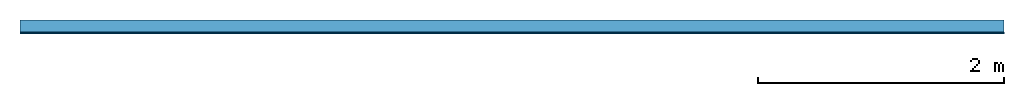
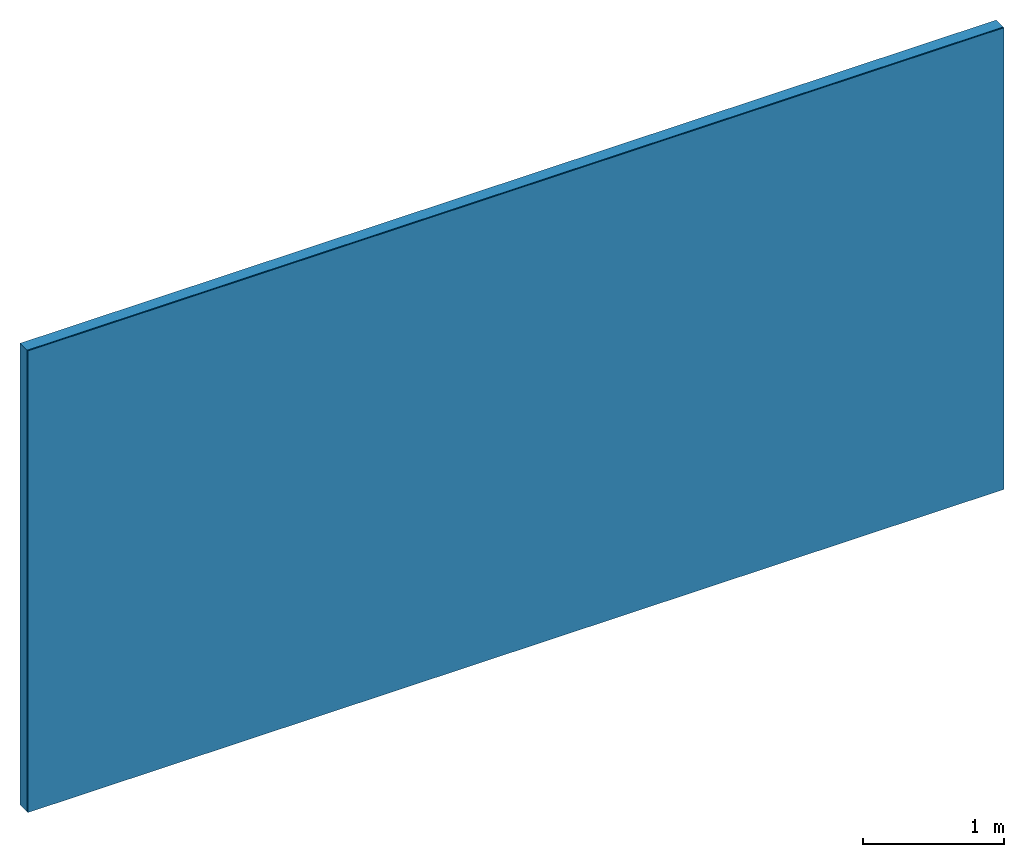
# One storey: 1 member, 1 plate, 1 element without a shape of its own.
"""IFC4 building model written with IfcOpenShell, lengths in metres."""

from ifc_helpers import new_model, si_unit, derived_unit, direction, frame, frame_2d, origin, place, context, project, spatial, rectangle, extrude, material, layer, layer_set, type_object, element, aggregate, save


model = new_model("IFC4")

# Units and contexts
plan_context = context("Plan", 3, precision=1e-05, world=origin(), true_north=direction((0.0, 1.0)))
model_context = context("Model", 3, precision=1e-05, world=origin(), true_north=direction((0.0, 1.0)))
ifc_project = project(units=[si_unit("LENGTHUNIT", "METRE"), derived_unit("SOUNDPRESSUREUNIT", [(si_unit("PRESSUREUNIT", "PASCAL", prefix="MICRO"), 0)]), si_unit("ENERGYUNIT", "JOULE", prefix="MEGA"), si_unit("MASSUNIT", "GRAM", prefix="KILO"), derived_unit("THERMALTRANSMITTANCEUNIT", [(si_unit("POWERUNIT", "WATT"), 1), (si_unit("AREAUNIT", "SQUARE_METRE"), -1), (si_unit("THERMODYNAMICTEMPERATUREUNIT", "KELVIN"), -1)]), derived_unit("AREADENSITYUNIT", [(si_unit("MASSUNIT", "GRAM", prefix="KILO"), 1), (si_unit("AREAUNIT", "SQUARE_METRE"), -1)]), derived_unit("USERDEFINED", [(si_unit("ENERGYUNIT", "JOULE", prefix="MEGA"), 1), (si_unit("AREAUNIT", "SQUARE_METRE"), -1)])], contexts=[plan_context, model_context])

# Site, building, storey
site = spatial("IfcSite", under=ifc_project)
building_placement = place(None, origin())
building = spatial("IfcBuilding", under=site, at=building_placement)
storey_placement = place(building_placement, origin())
storey = spatial("IfcBuildingStorey", under=building, at=storey_placement)

# Wall, member, plate
ifc_layer_1 = layer(None, 0.1, Name="Support")
ifc_material_1 = material(Name="Rigid, of the art")
ifc_layer_2 = layer(ifc_material_1, 0.0, Name="Bond")
ifc_material_2 = material(Name="Mineral Knauf SM 700")
ifc_layer_3 = layer(ifc_material_2, 0.01, Name="Surface")
ifc_layer_set = layer_set([ifc_layer_1, ifc_layer_2, ifc_layer_3])
wall_type = type_object("IfcWallType", Name="D1201", PredefinedType="NOTDEFINED", material=ifc_layer_set)
wall_placement = place(None, frame((0.0, 0.0, 0.0), z_axis=(0.0, -1.0, 0.0), x_axis=(1.0, 0.0, 0.0)))
wall = element("IfcWall", 1, at=wall_placement, inside=storey, type_object=wall_type, material=ifc_layer_set, Name="Wall #1")
ifc_material_3 = material(Name="OSB")
member_placement = place(wall_placement, origin())
member = element("IfcMember", 2, at=member_placement, material=ifc_material_3, Name="Support", context=plan_context, shape_type="SweptSolid", body=[
    extrude(rectangle(XDim=1.0, YDim=0.1, at=frame_2d((0.5, 0.05), x_axis=(1.0, 0.0))), frame((0.0, 4.0, 0.0), z_axis=(0.0, -1.0, 0.0), x_axis=(1.0, 0.0, 0.0)), (0.0, 0.0, 1.0), 4.0),
    extrude(rectangle(XDim=1.0, YDim=0.1, at=frame_2d((0.5, 0.05), x_axis=(1.0, 0.0))), frame((1.0, 4.0, 0.0), z_axis=(0.0, -1.0, 0.0), x_axis=(1.0, 0.0, 0.0)), (0.0, 0.0, 1.0), 4.0),
    extrude(rectangle(XDim=1.0, YDim=0.1, at=frame_2d((0.5, 0.05), x_axis=(1.0, 0.0))), frame((2.0, 4.0, 0.0), z_axis=(0.0, -1.0, 0.0), x_axis=(1.0, 0.0, 0.0)), (0.0, 0.0, 1.0), 4.0),
    extrude(rectangle(XDim=1.0, YDim=0.1, at=frame_2d((0.5, 0.05), x_axis=(1.0, 0.0))), frame((3.0, 4.0, 0.0), z_axis=(0.0, -1.0, 0.0), x_axis=(1.0, 0.0, 0.0)), (0.0, 0.0, 1.0), 4.0),
    extrude(rectangle(XDim=1.0, YDim=0.1, at=frame_2d((0.5, 0.05), x_axis=(1.0, 0.0))), frame((4.0, 4.0, 0.0), z_axis=(0.0, -1.0, 0.0), x_axis=(1.0, 0.0, 0.0)), (0.0, 0.0, 1.0), 4.0),
    extrude(rectangle(XDim=1.0, YDim=0.1, at=frame_2d((0.5, 0.05), x_axis=(1.0, 0.0))), frame((5.0, 4.0, 0.0), z_axis=(0.0, -1.0, 0.0), x_axis=(1.0, 0.0, 0.0)), (0.0, 0.0, 1.0), 4.0),
    extrude(rectangle(XDim=1.0, YDim=0.1, at=frame_2d((0.5, 0.05), x_axis=(1.0, 0.0))), frame((6.0, 4.0, 0.0), z_axis=(0.0, -1.0, 0.0), x_axis=(1.0, 0.0, 0.0)), (0.0, 0.0, 1.0), 4.0),
    extrude(rectangle(XDim=1.0, YDim=0.1, at=frame_2d((0.5, 0.05), x_axis=(1.0, 0.0))), frame((7.0, 4.0, 0.0), z_axis=(0.0, -1.0, 0.0), x_axis=(1.0, 0.0, 0.0)), (0.0, 0.0, 1.0), 4.0),
])
plate_placement = place(wall_placement, origin())
plate = element("IfcPlate", 3, at=plate_placement, material=ifc_material_2, Name="Surface", context=plan_context, shape_type="SweptSolid", body=[
    extrude(rectangle(XDim=8.0, YDim=4.0, at=frame_2d((4.0, 2.0), x_axis=(1.0, 0.0))), frame((0.0, 0.0, 0.1), z_axis=(0.0, 0.0, 1.0), x_axis=(1.0, 0.0, 0.0)), (0.0, 0.0, 1.0), 0.01),
])
aggregate(wall, [member, plate])

save(model, "model.ifc")
